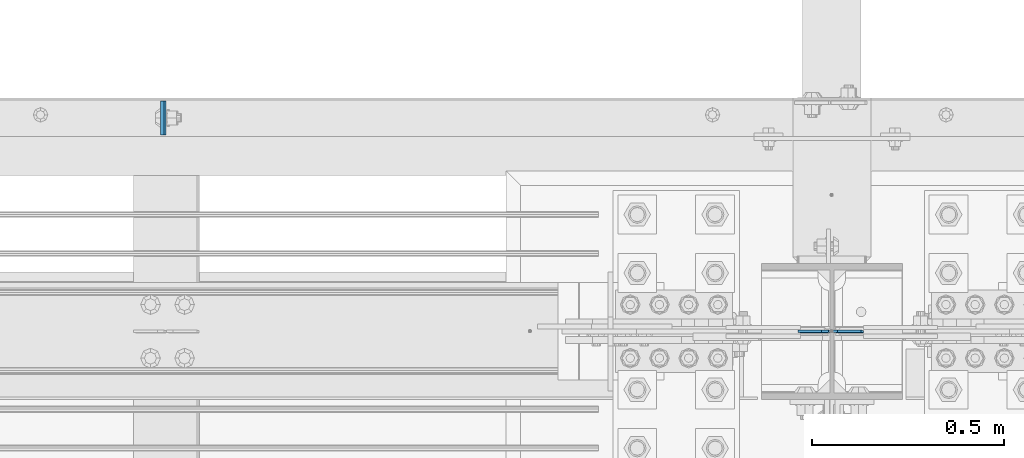
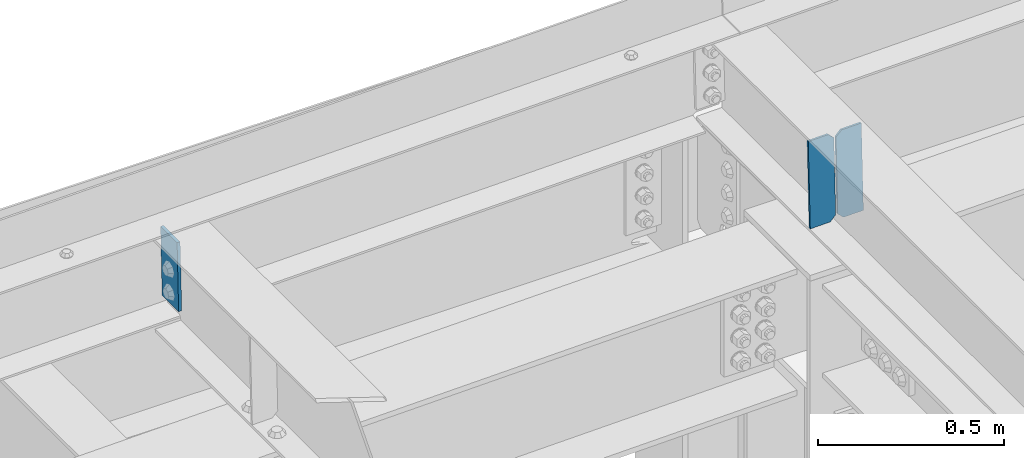
# One storey, part 3475 of 3843: 3 plates, 2 elements without a shape of their own.
"""IFC2X3 building model written with IfcOpenShell, lengths in millimetres."""

import ifcopenshell
import ifcopenshell.guid

model = None  # the IFC model being written
_history = None  # IfcOwnerHistory: only IFC2X3 demands one
_inside = {}  # id of a spatial element -> (the spatial element, [elements in it])
_under = {}  # id of a project, library or spatial element -> (it, [spatial elements below it])
_declared = {}  # id of a project -> (the project, [libraries it declares])
_typed = {}  # id of a type object -> (the type object, [elements of that type])
_made_of = {}  # id of a material, layer set ... -> (it, [elements and type objects made of it])


def new_model(schema):
    """Start an empty IFC model of exactly this schema.

    Asked for "IFC4X3", IfcOpenShell would pick the latest addendum, in which some entities
    have other attributes; the version numbers below select the first issue.
    IFC2X3 requires an IfcOwnerHistory on every rooted entity: one is made here for all.
    """
    global model, _history
    if schema == "IFC4X3":
        model = ifcopenshell.file(schema_version=(4, 3, 0, 0))
    else:
        model = ifcopenshell.file(schema=schema)
    _inside.clear()
    _under.clear()
    _declared.clear()
    _typed.clear()
    _made_of.clear()
    _history = None
    if model.schema == "IFC2X3":
        org = make("IfcOrganization", Name="unknown")
        user = make(
            "IfcPersonAndOrganization",
            ThePerson=make("IfcPerson", FamilyName="unknown"),
            TheOrganization=org,
        )
        app = make(
            "IfcApplication",
            ApplicationDeveloper=org,
            Version="unknown",
            ApplicationFullName="unknown",
            ApplicationIdentifier="unknown",
        )
        _history = make(
            "IfcOwnerHistory",
            OwningUser=user,
            OwningApplication=app,
            ChangeAction="ADDED",
            CreationDate=0,
        )
    return model


def make(cls, **values):
    """One entity of the class cls with the attributes given. An attribute that is None is left unset."""
    return model.create_entity(
        cls, **{name: value for name, value in values.items() if value is not None}
    )


def rooted(cls, **values):
    """An entity with a GlobalId (a new one), such as an element, a storey or a relation."""
    return make(cls, GlobalId=ifcopenshell.guid.new(), OwnerHistory=_history, **values)


def si_unit(unit_type, name, prefix=None):
    """IfcSIUnit, for example si_unit("LENGTHUNIT", "METRE", prefix="MILLI")."""
    return make("IfcSIUnit", UnitType=unit_type, Prefix=prefix, Name=name)


def assignment(units):
    """IfcUnitAssignment: the units of a project."""
    return None if units is None else make("IfcUnitAssignment", Units=units)


def point(xyz):
    """IfcCartesianPoint."""
    return None if xyz is None else make("IfcCartesianPoint", Coordinates=xyz)


def direction(xyz):
    """IfcDirection."""
    return None if xyz is None else make("IfcDirection", DirectionRatios=xyz)


def frame(location, z_axis=None, x_axis=None):
    """IfcAxis2Placement3D, a coordinate frame: its origin and axes. An axis left out is left unset."""
    return make(
        "IfcAxis2Placement3D",
        Location=point(location),
        Axis=direction(z_axis),
        RefDirection=direction(x_axis),
    )


def origin_with_axes():
    """The frame at (0, 0, 0) with the z axis (0, 0, 1) and the x axis (1, 0, 0) written out."""
    return frame((0.0, 0.0, 0.0), z_axis=(0.0, 0.0, 1.0), x_axis=(1.0, 0.0, 0.0))


def place(relative_to, where):
    """IfcLocalPlacement: puts the frame where relative to a parent placement (None: the world)."""
    return make(
        "IfcLocalPlacement", PlacementRelTo=relative_to, RelativePlacement=where
    )


def context(
    kind, dimensions, precision=None, world=None, true_north=None, identifier=None
):
    """IfcGeometricRepresentationContext, for example the 3D "Model" context."""
    return make(
        "IfcGeometricRepresentationContext",
        ContextIdentifier=identifier,
        ContextType=kind,
        CoordinateSpaceDimension=dimensions,
        Precision=precision,
        WorldCoordinateSystem=world,
        TrueNorth=true_north,
    )


def subcontext(parent, identifier, kind, view, scale=None):
    """IfcGeometricRepresentationSubContext, for example "Body" below "Model"."""
    return make(
        "IfcGeometricRepresentationSubContext",
        ContextIdentifier=identifier,
        ContextType=kind,
        ParentContext=parent,
        TargetScale=scale,
        TargetView=view,
    )


def project(units=None, contexts=None):
    """IfcProject with its units and contexts."""
    return rooted(
        "IfcProject",
        Name="project",
        RepresentationContexts=contexts,
        UnitsInContext=assignment(units),
    )


def spatial(cls, under=None, at=None, **own):
    """A site, building, storey or space (cls), placed at a placement, below another one or the project."""
    s = rooted(cls, ObjectPlacement=at, **own)
    if under is not None:
        _under.setdefault(under.id(), (under, []))[1].append(s)
    return s


def faces_of(points, faces, orient=None, outer=None):
    """IfcFace entities. A face is a list of loops; a loop is a list of indices into points, from 0.

    orient and outer hold one flag for each loop. By default every Orientation is true, the
    first loop of a face is its IfcFaceOuterBound and the others are IfcFaceBound.
    """
    made = []
    for i, loops in enumerate(faces):
        bounds = []
        for j, loop in enumerate(loops):
            is_outer = j == 0 if outer is None else outer[i][j]
            bounds.append(
                make(
                    "IfcFaceOuterBound" if is_outer else "IfcFaceBound",
                    Bound=make("IfcPolyLoop", Polygon=[points[k] for k in loop]),
                    Orientation=True if orient is None else orient[i][j],
                )
            )
        made.append(make("IfcFace", Bounds=bounds))
    return made


def faceted_brep(points, faces, orient=None, outer=None, voids=None):
    """IfcFacetedBrep: a solid bounded by flat faces; with voids (closed shells), ...WithVoids."""
    shared = [point(p) for p in points]
    hull = make("IfcClosedShell", CfsFaces=faces_of(shared, faces, orient, outer))
    if voids is None:
        return make("IfcFacetedBrep", Outer=hull)
    return make(
        "IfcFacetedBrepWithVoids",
        Outer=hull,
        Voids=[
            make(cls, CfsFaces=faces_of(shared, fs, o, b)) for cls, fs, o, b in voids
        ],
    )


def shape(context_of_items, identifier, shape_type, items):
    """IfcShapeRepresentation: the items that make up one representation, for example the "Body"."""
    return make(
        "IfcShapeRepresentation",
        ContextOfItems=context_of_items,
        RepresentationIdentifier=identifier,
        RepresentationType=shape_type,
        Items=items,
    )


def material(Name=None, Category=None):
    """IfcMaterial."""
    return make("IfcMaterial", Name=Name, Category=Category)


def made_of(thing, what):
    """Note that an element or type object is made of a material, layer set ...; save() writes the relation."""
    if what is not None:
        _made_of.setdefault(what.id(), (what, []))[1].append(thing)
    return thing


def type_object(cls, material=None, **own):
    """A type object (cls), such as IfcWallType, which elements share."""
    return made_of(rooted(cls, **own), material)


def element(
    cls,
    number,
    at=None,
    inside=None,
    cuts=None,
    type_object=None,
    material=None,
    context=None,
    identifier="Body",
    shape_type=None,
    held_by="IfcProductDefinitionShape",
    body=None,
    shapes=None,
    **own,
):
    """One element of the class cls, such as IfcWall. Its Tag is "e" and its number.

    at: its placement. inside: the storey or other place that contains it. cuts: it is an
    opening in that element (IfcRelVoidsElement). A single representation is given by context,
    identifier, shape_type and body (its items); several are given by shapes. held_by: the class
    of the entity that holds the representations. save() writes the other relations.
    """
    e = rooted(cls, Tag="e%d" % number, ObjectPlacement=at, **own)
    if body is not None:
        shapes = [shape(context, identifier, shape_type, body)]
    if shapes is not None:
        e.Representation = make(held_by, Representations=shapes)
    if inside is not None:
        _inside.setdefault(inside.id(), (inside, []))[1].append(e)
    if cuts is not None:
        rooted(
            "IfcRelVoidsElement", RelatingBuildingElement=cuts, RelatedOpeningElement=e
        )
    if type_object is not None:
        _typed.setdefault(type_object.id(), (type_object, []))[1].append(e)
    return made_of(e, material)


def aggregate(whole, parts):
    """IfcRelAggregates: a whole, such as a stair, and the parts it consists of."""
    return rooted("IfcRelAggregates", RelatingObject=whole, RelatedObjects=parts)


def save(model, path):
    """Write the relations noted so far, then the file.

    IfcRelAggregates (storeys below a building ...), IfcRelContainedInSpatialStructure (elements
    in a storey), IfcRelDefinesByType, IfcRelAssociatesMaterial and IfcRelDeclares: one each for
    every whole, place, type object, material and project.
    """
    for whole, parts in _under.values():
        aggregate(whole, parts)
    for where, things in _inside.values():
        rooted(
            "IfcRelContainedInSpatialStructure",
            RelatedElements=things,
            RelatingStructure=where,
        )
    for kind, things in _typed.values():
        rooted("IfcRelDefinesByType", RelatedObjects=things, RelatingType=kind)
    for what, things in _made_of.values():
        rooted("IfcRelAssociatesMaterial", RelatedObjects=things, RelatingMaterial=what)
    for by, libraries in _declared.values():
        rooted("IfcRelDeclares", RelatingContext=by, RelatedDefinitions=libraries)
    model.write(path)


model = new_model("IFC2X3")

# Units and contexts
model_context = context("Model", 3, precision=1e-05, world=origin_with_axes())
body_context = subcontext(model_context, "Body", "Model", "MODEL_VIEW")
ifc_project = project(units=[si_unit("LENGTHUNIT", "METRE", prefix="MILLI"), si_unit("AREAUNIT", "SQUARE_METRE"), si_unit("VOLUMEUNIT", "CUBIC_METRE"), si_unit("MASSUNIT", "GRAM", prefix="KILO"), si_unit("TIMEUNIT", "SECOND"), si_unit("PLANEANGLEUNIT", "RADIAN"), si_unit("SOLIDANGLEUNIT", "STERADIAN"), si_unit("THERMODYNAMICTEMPERATUREUNIT", "DEGREE_CELSIUS"), si_unit("LUMINOUSINTENSITYUNIT", "LUMEN")], contexts=[model_context])

# Site, building, storey
site_placement = place(None, origin_with_axes())
site = spatial("IfcSite", under=ifc_project, at=site_placement, CompositionType="ELEMENT")
building_placement = place(site_placement, origin_with_axes())
building = spatial("IfcBuilding", under=site, at=building_placement, Name="Undefined", CompositionType="ELEMENT")
storey_placement = place(building_placement, origin_with_axes())
storey = spatial("IfcBuildingStorey", under=building, at=storey_placement, Name="Undefined", CompositionType="ELEMENT", Elevation=0.0)

# Assembly, plate
assembly_1_placement = place(storey_placement, origin_with_axes())
assembly_1 = element("IfcElementAssembly", 1, at=assembly_1_placement, inside=storey, Name="CHANNEL", AssemblyPlace="NOTDEFINED", PredefinedType="RIGID_FRAME")
ifc_material = material(Name="STEEL/A572-50")
plate_type_1 = type_object("IfcPlateType", PredefinedType="NOTDEFINED")
plate_1_placement = place(assembly_1_placement, frame((54183.5377917799, 92816.3624021162, 46064.0563112041), z_axis=(2.03399930251182e-05, -0.99999999979305, 4.30329600931148e-07), x_axis=(0.0211520550054438, 0.0, -0.999776270257025)))
plate_1 = element("IfcPlate", 2, at=plate_1_placement, type_object=plate_type_1, material=ifc_material, Name="PLATE", context=body_context, shape_type="Brep", body=[
    faceted_brep([(0.0, -4.76249999999709, 0.0), (0.0, -4.76249999999709, 88.9000015258789), (0.0, 4.76249999999709, 88.9000015258789), (0.0, 4.76249999999709, 0.0), (228.600006102781, -4.7625000004191, 88.9000015257589), (228.600006102781, 4.76249999954598, 88.9000015257443), (228.600006103079, -4.7625000004482, 7.27595761418343e-12), (228.600006103079, 4.76249999954598, -7.27595761418343e-12)], [[[0, 1, 2, 3]], [[1, 4, 5, 2]], [[4, 6, 7, 5]], [[6, 0, 3, 7]], [[5, 7, 3, 2]], [[6, 4, 1, 0]]]),
])
aggregate(assembly_1, [plate_1])

# Assembly, plates
assembly_2_placement = place(storey_placement, origin_with_axes())
assembly_2 = element("IfcElementAssembly", 3, at=assembly_2_placement, inside=storey, Name="BEAM", AssemblyPlace="NOTDEFINED", PredefinedType="RIGID_FRAME")
plate_type_2 = type_object("IfcPlateType", PredefinedType="NOTDEFINED")
plate_2_placement = place(assembly_2_placement, frame((56013.0964783642, 92214.3020283802, 45841.3618119285), z_axis=(-0.0211520978111003, 0.00105623000043852, 0.999775711415503), x_axis=(-0.999776269351393, -2.23460000402641e-05, -0.0211520860074533)))
plate_2 = element("IfcPlate", 4, at=plate_2_placement, type_object=plate_type_2, material=ifc_material, Name="STIFFENER", context=body_context, shape_type="Brep", body=[
    faceted_brep([(0.0, -3.17499999999927, 0.0), (6.83940015733242e-10, -3.17499999996653, 288.924999998613), (6.54836185276508e-10, 3.17500000001746, 288.924999998591), (0.0, 3.17499999999927, 0.0), (61.9125003828667, -3.17499999997744, 288.924999998599), (61.9125003828522, 3.17500000002838, 288.924999998584), (79.3750000013097, -3.17499999997744, 271.462500380039), (79.375000001266, 3.17500000002838, 271.462500380017), (79.375000000713, -3.17499999999927, 17.4624996185448), (79.3750000006694, 3.17500000000291, 17.462499618523), (61.9125003821828, -3.17499999999563, -1.45519152283669e-11), (61.9125003821682, 3.17500000000655, -2.91038304567337e-11)], [[[0, 1, 2, 3]], [[1, 4, 5, 2]], [[4, 6, 7, 5]], [[6, 8, 9, 7]], [[8, 10, 11, 9]], [[10, 0, 3, 11]], [[5, 7, 9, 11, 3, 2]], [[10, 8, 6, 4, 1, 0]]]),
])
plate_3_placement = place(assembly_2_placement, frame((55927.3906576745, 92214.3001127275, 45839.5485493383), z_axis=(-0.0211520978111003, 0.00105623000043852, 0.999775711415503), x_axis=(-0.999776269351393, -2.23460000402641e-05, -0.0211520860074533)))
plate_3 = element("IfcPlate", 5, at=plate_3_placement, type_object=plate_type_2, material=ifc_material, Name="STIFFENER", context=body_context, shape_type="Brep", body=[
    faceted_brep([(5.82076609134674e-11, -3.17499999999927, 17.4624996185667), (6.25732354819775e-10, -3.17499999997744, 271.462500380054), (5.82076609134674e-10, 3.17500000002474, 271.462500380039), (0.0, 3.17500000000655, 17.4624996185521), (17.462499619156, -3.17499999997744, 288.924999998606), (17.4624996191269, 3.17500000002474, 288.924999998591), (79.3750000013242, -3.17500000025029, 288.924999998591), (79.3750000013097, 3.1749999997337, 288.92499999857), (79.3750000006548, -3.17500000026484, -2.18278728425503e-11), (79.3750000006403, 3.17499999969732, -2.91038304567337e-11), (17.4624996184866, -3.17500000000291, 7.27595761418343e-12), (17.462499618443, 3.17500000000291, -7.27595761418343e-12)], [[[0, 1, 2, 3]], [[1, 4, 5, 2]], [[4, 6, 7, 5]], [[6, 8, 9, 7]], [[8, 10, 11, 9]], [[10, 0, 3, 11]], [[5, 7, 9, 11, 3, 2]], [[10, 8, 6, 4, 1, 0]]]),
])
aggregate(assembly_2, [plate_2, plate_3])

save(model, "model.ifc")
